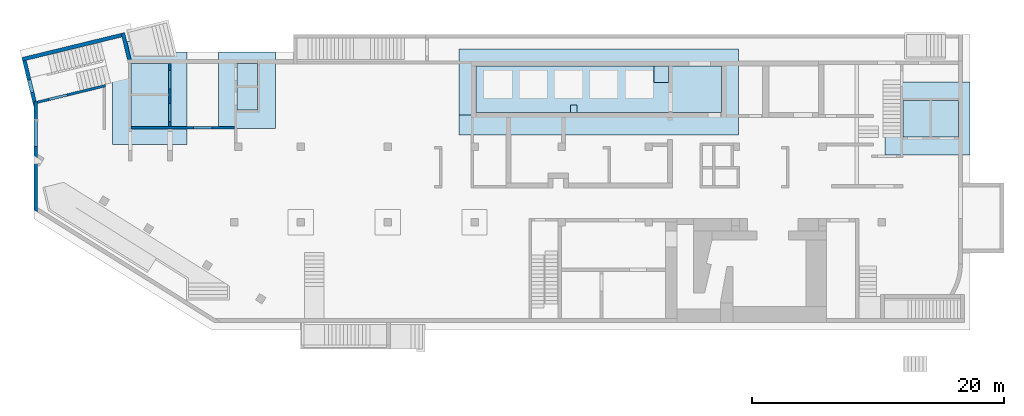
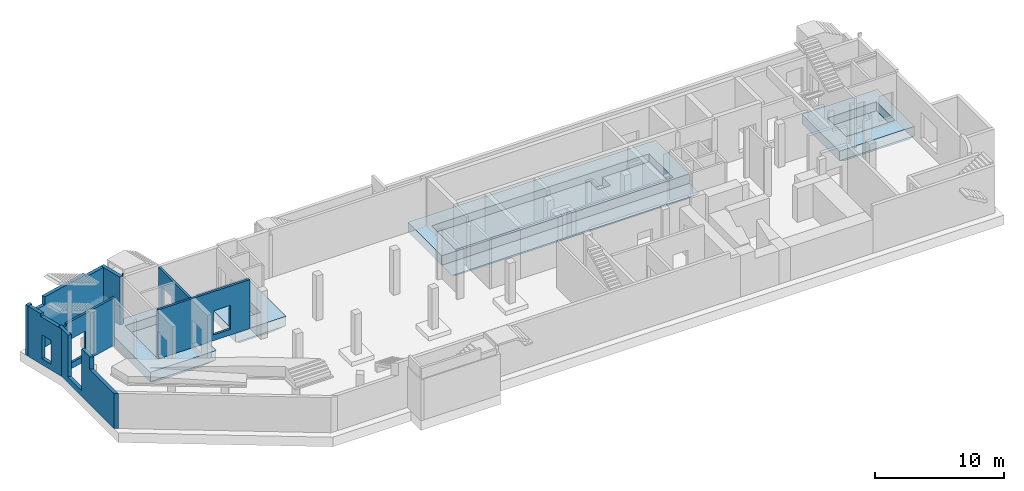
# One storey, part 5 of 9: 7 walls, 4 slabs, 7 openings.
"""IFC4 building model written with IfcOpenShell, lengths in millimetres."""

from ifc_helpers import new_model, entity, si_unit, converted_unit, derived_unit, direction, frame, origin, place, context, subcontext, project, spatial, indexed_curve, outline, extrude, polygons, material, type_object, element, save


model = new_model("IFC4")

# Units and contexts
model_context = context("Model", 3, precision=0.01, world=origin(), true_north=direction((6.12303176911189e-17, 1.0)))
plan_context = context("Plan", 3, precision=0.01, world=origin(), true_north=direction((6.12303176911189e-17, 1.0)))
body_context = subcontext(model_context, "Body", "Model", "MODEL_VIEW")
ifc_project = project(units=[si_unit("LENGTHUNIT", "METRE", prefix="MILLI"), si_unit("AREAUNIT", "SQUARE_METRE"), si_unit("VOLUMEUNIT", "CUBIC_METRE"), converted_unit("PLANEANGLEUNIT", "DEGREE", entity("IfcRatioMeasure", 0.0174532925199433), si_unit("PLANEANGLEUNIT", "RADIAN"), dimensions=[0, 0, 0, 0, 0, 0, 0]), si_unit("MASSUNIT", "GRAM", prefix="KILO"), derived_unit("MASSDENSITYUNIT", [(si_unit("MASSUNIT", "GRAM", prefix="KILO"), 1), (si_unit("LENGTHUNIT", "METRE"), -3)]), derived_unit("MOMENTOFINERTIAUNIT", [(si_unit("LENGTHUNIT", "METRE"), 4)]), si_unit("TIMEUNIT", "SECOND"), si_unit("FREQUENCYUNIT", "HERTZ"), si_unit("THERMODYNAMICTEMPERATUREUNIT", "DEGREE_CELSIUS"), derived_unit("THERMALTRANSMITTANCEUNIT", [(si_unit("MASSUNIT", "GRAM", prefix="KILO"), 1), (si_unit("THERMODYNAMICTEMPERATUREUNIT", "KELVIN"), -1), (si_unit("TIMEUNIT", "SECOND"), -3)]), derived_unit("VOLUMETRICFLOWRATEUNIT", [(si_unit("LENGTHUNIT", "METRE"), 3), (si_unit("TIMEUNIT", "SECOND"), -1)]), derived_unit("MASSFLOWRATEUNIT", [(si_unit("MASSUNIT", "GRAM", prefix="KILO"), 1), (si_unit("TIMEUNIT", "SECOND"), -1)]), derived_unit("ROTATIONALFREQUENCYUNIT", [(si_unit("TIMEUNIT", "SECOND"), -1)]), si_unit("ELECTRICCURRENTUNIT", "AMPERE"), si_unit("ELECTRICVOLTAGEUNIT", "VOLT"), si_unit("POWERUNIT", "WATT"), si_unit("FORCEUNIT", "NEWTON", prefix="KILO"), si_unit("ILLUMINANCEUNIT", "LUX"), si_unit("LUMINOUSFLUXUNIT", "LUMEN"), si_unit("LUMINOUSINTENSITYUNIT", "CANDELA"), derived_unit("USERDEFINED", [(si_unit("MASSUNIT", "GRAM", prefix="KILO"), -1), (si_unit("LENGTHUNIT", "METRE"), -2), (si_unit("TIMEUNIT", "SECOND"), 3), (si_unit("LUMINOUSFLUXUNIT", "LUMEN"), 1)]), derived_unit("LINEARVELOCITYUNIT", [(si_unit("LENGTHUNIT", "METRE"), 1), (si_unit("TIMEUNIT", "SECOND"), -1)]), si_unit("PRESSUREUNIT", "PASCAL"), derived_unit("USERDEFINED", [(si_unit("LENGTHUNIT", "METRE"), -2), (si_unit("MASSUNIT", "GRAM", prefix="KILO"), 1), (si_unit("TIMEUNIT", "SECOND"), -2)]), derived_unit("LINEARFORCEUNIT", [(si_unit("MASSUNIT", "GRAM", prefix="KILO"), 1), (si_unit("LENGTHUNIT", "METRE"), 1), (si_unit("TIMEUNIT", "SECOND"), -2), (si_unit("LENGTHUNIT", "METRE"), -1)]), derived_unit("PLANARFORCEUNIT", [(si_unit("MASSUNIT", "GRAM", prefix="KILO"), 1), (si_unit("LENGTHUNIT", "METRE"), 1), (si_unit("TIMEUNIT", "SECOND"), -2), (si_unit("LENGTHUNIT", "METRE"), -2)])], contexts=[model_context, plan_context])

# Site, building, storey
site_placement = place(None, origin())
site = spatial("IfcSite", under=ifc_project, at=site_placement, CompositionType="ELEMENT")
building_placement = place(site_placement, origin())
building = spatial("IfcBuilding", under=site, at=building_placement, CompositionType="ELEMENT")
storey_placement = place(building_placement, frame((0.0, 0.0, -4900.0)))
storey = spatial("IfcBuildingStorey", under=building, at=storey_placement, CompositionType="ELEMENT", Elevation=-4900.0)

# Slabs
ifc_material = material()
slab_type_1 = type_object("IfcSlabType", PredefinedType="BASESLAB", material=ifc_material)
slab_1_placement = place(storey_placement, frame((67520.0, 13020.0, -1750.0)))
element("IfcSlab", 1, at=slab_1_placement, inside=storey, type_object=slab_type_1, PredefinedType="BASESLAB", context=body_context, shape_type="Tessellation", body=[
    polygons([(1450.00000000004, 4349.99999999999, 1750.0), (5850.00000000005, 4349.99999999999, 1750.0), (5850.00000000005, 1449.99999999998, 1750.0), (1450.00000000004, 1449.99999999998, 1750.0), (6750.00000000002, 5799.99999999999, 1750.0), (4.33146851719357e-11, 5799.99999999999, 1750.0), (4.33146851719357e-11, -2.16573425859679e-12, 1750.0), (6750.00000000002, -2.16573425859679e-12, 1750.0), (6750.00000000002, 4949.99999999999, 0.0), (6750.00000000002, 850.000000000025, 0.0), (850.000000000006, 850.000000000025, 0.0), (850.000000000023, 4949.99999999999, 0.0), (6750.00000000002, 5799.99999999999, 849.999999999998), (4.33146851719357e-11, 5799.99999999999, 849.999999999997), (3.46517481375486e-11, 1.51601398101775e-11, 849.999999999995), (6750.00000000002, -2.16573425859679e-12, 850.00000000002), (5850.00000000005, 4349.99999999999, 899.999999999999), (3750.00000000004, 4349.99999999999, 899.999999999999), (3550.00000000004, 4349.99999999999, 899.999999999999), (1450.00000000004, 4349.99999999999, 899.999999999999), (1450.00000000004, 1449.99999999998, 899.999999999999), (3550.00000000003, 1449.99999999998, 899.999999999999), (3750.00000000003, 1449.99999999998, 899.999999999999), (5850.00000000005, 1449.99999999998, 899.999999999999)], [[[5, 6, 7, 8], [1, 2, 3, 4]], [[9, 10, 11, 12]], [[6, 5, 13, 14]], [[7, 6, 14, 15]], [[8, 7, 15, 16]], [[5, 8, 16, 10, 9, 13]], [[11, 10, 16, 15]], [[9, 12, 14, 13]], [[12, 11, 15, 14]], [[17, 18, 19, 20, 21, 22, 23, 24]], [[2, 1, 20, 19, 18, 17]], [[1, 4, 21, 20]], [[4, 3, 24, 23, 22, 21]], [[3, 2, 17, 24]]], closed=True),
])
slab_type_2 = type_object("IfcSlabType", PredefinedType="BASESLAB", material=ifc_material)
slab_2_placement = place(storey_placement, frame((14650.0, 15150.0, -1750.0)))
element("IfcSlab", 2, at=slab_2_placement, inside=storey, type_object=slab_type_2, PredefinedType="BASESLAB", context=body_context, shape_type="Tessellation", body=[
    polygons([(-2.16573425859679e-12, 6050.00000000001, 1750.00000000001), (1.08286712929839e-11, 0.0, 1750.00000000001), (4525.0, 8.66293703438714e-12, 1750.00000000001), (4524.99999999999, 6050.00000000001, 1750.00000000001), (1450.00000000001, 1450.0, 1750.0), (1450.0, 5150.0, 1750.0), (3075.0, 5150.00000000001, 1750.0), (3075.0, 5100.00000000023, 1750.00000000001), (3075.00000000001, 1450.00000000001, 1750.0), (849.999999999993, 6050.00000000001, 4.33146851719357e-12), (3674.99999999997, 6050.00000000001, 3.24860138789518e-12), (3674.99999999998, 849.99999999998, 5.41433564649196e-12), (850.000000000002, 849.999999999995, 3.24860138789518e-12), (-2.16573425859679e-12, 6050.00000000001, 850.0), (1.08286712929839e-11, 0.0, 850.000000000001), (4524.99999999998, 6.49720277579036e-12, 850.000000000001), (4524.99999999999, 6050.00000000001, 850.00000000002), (1450.0, 5150.0, 900.000000000003), (1450.00000000001, 1450.0, 900.000000000003), (3075.00000000001, 1450.00000000001, 900.000000000003), (3075.0, 5150.00000000001, 900.000000000003)], [[[1, 2, 3, 4], [5, 6, 7, 8, 9]], [[10, 11, 12, 13]], [[2, 1, 14, 15]], [[3, 2, 15, 16]], [[4, 3, 16, 17]], [[1, 4, 17, 11, 10, 14]], [[12, 11, 17, 16]], [[10, 13, 15, 14]], [[13, 12, 16, 15]], [[18, 19, 20, 21]], [[6, 5, 19, 18]], [[5, 9, 20, 19]], [[9, 8, 7, 21, 20]], [[7, 6, 18, 21]]], closed=True),
])
slab_type_3 = type_object("IfcSlabType", PredefinedType="BASESLAB", material=ifc_material)
slab_3_placement = place(storey_placement, frame((6250.0, 13850.0, -1750.0)))
element("IfcSlab", 3, at=slab_3_placement, inside=storey, type_object=slab_type_3, PredefinedType="BASESLAB", context=body_context, shape_type="Tessellation", body=[
    polygons([(-1.08286712929839e-12, 8200.00000000004, 1750.00000000001), (1.40772726808791e-11, 3.68174823961454e-11, 1750.00000000001), (5900.00000000001, 4.54804194305325e-11, 1750.00000000001), (5900.0, 7350.00000000009, 1750.00000000001), (1950.50878437107, 7350.0000000001, 1750.0), (1743.31229154819, 8200.00000000004, 1750.00000000001), (1450.00000000001, 1450.00000000004, 1750.0), (1450.0, 6450.00000000009, 1750.0), (4450.0, 6450.0000000001, 1750.0), (4450.00000000001, 1450.00000000005, 1750.0), (5049.99999999999, 849.999999999991, 3.24860138789518e-12), (850.000000000003, 850.000000000015, 4.33146851719357e-12), (849.999999999993, 7350.00000000009, 3.24860138789518e-12), (1950.50878437107, 7350.0000000001, 4.33146851719357e-12), (5049.99999999998, 7350.00000000009, 5.41433564649196e-12), (3.24860138789518e-12, 8200.00000000005, 849.999999999984), (1.40772726808791e-11, 3.46517481375486e-11, 849.999999999995), (5900.00000000001, 3.46517481375486e-11, 849.999999999996), (5900.0, 7350.00000000009, 850.00000000002), (1743.31229154819, 8200.00000000004, 849.999999999957), (1450.0, 6450.00000000009, 900.000000000003), (1450.00000000001, 1450.00000000004, 900.000000000003), (4450.00000000001, 1450.00000000005, 900.000000000003), (4450.0, 6450.0000000001, 900.000000000003)], [[[1, 2, 3, 4, 5, 6], [7, 8, 9, 10]], [[11, 12, 13, 14, 15]], [[2, 1, 16, 17]], [[3, 2, 17, 18]], [[3, 18, 19, 4]], [[16, 1, 6, 20]], [[18, 11, 15, 19]], [[17, 16, 13, 12]], [[12, 11, 18, 17]], [[21, 22, 23, 24]], [[8, 7, 22, 21]], [[7, 10, 23, 22]], [[10, 9, 24, 23]], [[9, 8, 21, 24]], [[13, 16, 20, 14]], [[5, 4, 19, 15, 14]], [[6, 5, 14, 20]]], closed=True),
])
slab_type_4 = type_object("IfcSlabType", PredefinedType="BASESLAB", material=ifc_material)
slab_4_placement = place(storey_placement, frame((33720.0, 14600.0, -1800.0)))
element("IfcSlab", 4, at=slab_4_placement, inside=storey, type_object=slab_type_4, PredefinedType="BASESLAB", context=body_context, shape_type="Tessellation", body=[
    polygons([(22200.0, 6850.00000000012, 1800.0), (-4.33146851719357e-12, 6850.00000000008, 1800.0), (8.66293703438714e-12, 1600.00000000008, 1800.0), (22200.0, 1600.00000000012, 1800.0), (20850.0, 5500.00000000027, 1800.00000000001), (20850.0, 1800.00000000025, 1800.00000000001), (1350.00000000001, 1800.00000000021, 1800.00000000001), (1350.00000000001, 5500.00000000024, 1800.00000000001), (21450.0, 750.000000000005, 150.000000000005), (750.00000000002, 750.000000000109, 150.000000000004), (750.000000000016, 3850.00000000021, 150.000000000005), (750.000000000011, 6100.00000000015, 150.000000000005), (15150.0, 6100.00000000015, 150.000000000005), (15150.0, 5500.00000000026, 150.000000000005), (15150.0, 3850.00000000016, 150.000000000002), (17000.0, 3850.00000000016, 150.000000000008), (17000.0, 5500.00000000026, 150.000000000005), (17000.0, 6100.00000000015, 150.000000000006), (21450.0, 6100.00000000015, 150.000000000005), (21450.0, 3850.00000000015, 150.000000000005), (4.33146851719357e-12, 6850.00000000009, 899.999999999995), (1.29944055515807e-11, 1600.00000000008, 900.000000000014), (22200.0, 6850.00000000012, 899.99999999999), (22200.0, 1600.00000000012, 900.000000000003), (1350.00000000001, 5500.00000000024, 1050.00000000001), (15500.0, 5500.00000000023, 1050.00000000001), (15500.0, 5500.00000000017, 300.000000000005), (16650.0, 5500.0000000002, 300.000000000005), (16650.0, 5500.00000000027, 1050.00000000001), (16950.0, 5500.00000000027, 1050.00000000001), (20850.0, 5500.00000000027, 1050.00000000001), (15300.0, 5950.00000000015, 3.24860138789518e-12), (16850.0, 5950.00000000015, 5.41433564649196e-12), (16850.0, 4000.00000000016, 7.58006990508875e-12), (15300.0, 4000.00000000016, 7.58006990508875e-12), (22200.0, 5.84748249821132e-11, 899.999999999991), (1.29944055515807e-11, 9.52923073782586e-11, 900.000000000013), (1350.00000000001, 1800.00000000021, 1050.00000000001), (8860.00000000002, 1800.00000000022, 1050.00000000001), (8860.00000000002, 2400.00000000022, 1050.00000000001), (9360.00000000002, 2400.00000000022, 1050.00000000001), (9360.00000000002, 1800.00000000022, 1050.00000000001), (16650.0, 1800.00000000024, 1050.00000000001), (16950.0, 1800.00000000024, 1050.00000000001), (20850.0, 1800.00000000025, 1050.00000000001), (16650.0, 4200.00000000016, 1050.00000000001), (15500.0, 4200.00000000016, 1050.00000000001), (9360.00000000002, 1800.00000000022, 800.000000000005), (8860.00000000002, 1800.00000000022, 800.000000000005), (9360.00000000002, 2400.00000000022, 800.000000000005), (8860.00000000002, 2400.00000000022, 800.000000000005), (15500.0, 4200.00000000016, 300.000000000005), (16650.0, 4200.00000000016, 300.000000000005)], [[[1, 2, 3, 4], [5, 6, 7, 8]], [[9, 10, 11, 12, 13, 14, 15, 16, 17, 18, 19, 20]], [[2, 21, 22, 3]], [[23, 1, 4, 24]], [[2, 1, 23, 21]], [[8, 25, 26, 27, 28, 29, 30, 31, 5]], [[32, 33, 34, 35]], [[20, 19, 23, 24, 36, 9]], [[11, 10, 37, 22, 21, 12]], [[10, 9, 36, 37]], [[25, 38, 39, 40, 41, 42, 43, 44, 45, 31, 30, 29, 46, 47, 26]], [[8, 7, 38, 25]], [[7, 6, 45, 44, 43, 42, 48, 49, 39, 38]], [[6, 5, 31, 45]], [[33, 32, 13, 12, 21, 23, 19, 18]], [[49, 48, 50, 51]], [[42, 41, 50, 48]], [[41, 40, 51, 50]], [[40, 39, 49, 51]], [[35, 34, 16, 15]], [[34, 33, 18, 17, 16]], [[32, 35, 15, 14, 13]], [[28, 27, 52, 53]], [[26, 47, 52, 27]], [[47, 46, 53, 52]], [[46, 29, 28, 53]], [[24, 22, 37, 36]], [[22, 24, 4, 3]]], closed=True),
])

# Wall, openings
wall_type_1 = type_object("IfcWallType", Name=":ADSK_ 25_200", PredefinedType="STANDARD")
wall_1_placement = place(storey_placement, frame((10800.0, 20300.0, 0.0), z_axis=(0.0, 0.0, 1.0), x_axis=(0.0, -1.0, 0.0)))
wall_1 = element("IfcWall", 5, at=wall_1_placement, inside=storey, type_object=wall_type_1, material=ifc_material, Name=":ADSK_ 25_200", ObjectType=":ADSK_ 25_200", PredefinedType="NOTDEFINED", context=body_context, shape_type="Tessellation", body=[
    polygons([(579.999999999998, -100.000000000002, 2919.99999999804), (2020.0, -100.000000000002, 2919.99999999804), (2020.0, -100.000000000002, 550.0), (579.999999999998, -100.000000000002, 550.0), (3180.0, -100.000000000002, 2919.99999999804), (4620.0, -100.000000000002, 2919.99999999804), (4620.0, -100.000000000002, 550.0), (3180.0, -100.000000000002, 550.0), (0.0, -100.000000000002, 0.0), (2399.99999999999, -100.000000000001, 0.0), (2599.99999999999, -100.000000000001, 0.0), (5000.00000000048, -100.000000000002, 0.0), (5000.00000000048, -100.000000000002, 4500.0), (0.0, -100.000000000002, 4500.0), (5000.00000000048, 99.9999999999976, 0.0), (0.0, 99.9999999999985, 0.0), (0.0, 99.9999999999985, 4500.0), (5000.00000000048, 99.9999999999976, 4500.0), (2020.0, 99.9999999999977, 2919.99999999804), (579.999999999998, 99.9999999999976, 2919.99999999804), (579.999999999998, 99.9999999999976, 550.0), (2020.0, 99.9999999999977, 550.0), (4620.0, 99.9999999999982, 2919.99999999804), (3180.0, 99.9999999999981, 2919.99999999804), (3180.0, 99.9999999999981, 550.0), (4620.0, 99.9999999999982, 550.0)], [[[9, 10, 11, 12, 13, 14], [1, 2, 3, 4], [5, 6, 7, 8]], [[15, 16, 17, 18], [19, 20, 21, 22], [23, 24, 25, 26]], [[12, 11, 10, 9, 16, 15]], [[14, 13, 18, 17]], [[9, 14, 17, 16]], [[13, 12, 15, 18]], [[19, 2, 1, 20]], [[20, 1, 4, 21]], [[21, 4, 3, 22]], [[2, 19, 22, 3]], [[23, 6, 5, 24]], [[24, 5, 8, 25]], [[25, 8, 7, 26]], [[6, 23, 26, 7]]], closed=True),
])
placement_1 = place(wall_1_placement, frame((20300.0, -10800.0, 0.0), z_axis=(0.0, 0.0, 1.0), x_axis=(0.0, 1.0, 0.0)))
element("IfcOpeningElement", 6, at=placement_1, cuts=wall_1, Name=":ADSK_ 25_200", PredefinedType="OPENING", context=body_context, shape_type="SweptSolid", body=[
    extrude(outline(indexed_curve([(-1184.99999999902, -719.999999999999), (1184.99999999902, -719.999999999999), (1184.99999999902, 720.000000000001), (-1184.99999999902, 720.000000000001), (-1184.99999999902, -719.999999999999)], self_intersect=False)), frame((10600.0, 19000.0, 1735.0), z_axis=(1.0, 0.0, 0.0), x_axis=(0.0, 0.0, -1.0)), (0.0, 0.0, 1.0), 400.000000001943),
])
element("IfcOpeningElement", 7, at=placement_1, cuts=wall_1, Name=":ADSK_ 25_200", PredefinedType="OPENING", context=body_context, shape_type="SweptSolid", body=[
    extrude(outline(indexed_curve([(-1184.99999999902, -719.999999999999), (1184.99999999902, -719.999999999999), (1184.99999999902, 720.000000000001), (-1184.99999999902, 720.000000000001), (-1184.99999999902, -719.999999999999)], self_intersect=False)), frame((10600.0, 16400.0, 1735.0), z_axis=(1.0, 0.0, 0.0), x_axis=(0.0, 0.0, -1.0)), (0.0, 0.0, 1.0), 400.000000001943),
])

# Wall, opening
wall_2_placement = place(storey_placement, frame((7700.0, 15200.0, 0.0)))
wall_2 = element("IfcWall", 8, at=wall_2_placement, inside=storey, type_object=wall_type_1, material=ifc_material, Name=":ADSK_ 25_200", ObjectType=":ADSK_ 25_200", PredefinedType="NOTDEFINED", context=body_context, shape_type="Tessellation", body=[
    polygons([(1.8769719247939e-12, -100.000000000001, 0.0), (99.9999999999986, -100.000000000001, 0.0), (2900.0, -100.000000000001, 0.0), (3300.0, -99.9999999999989, 0.0), (8199.99999999999, -99.9999999999989, 0.0), (8199.99999999999, -99.9999999999989, 4650.0), (3300.0, -99.9999999999989, 4650.0), (2900.0, -100.000000000001, 4650.0), (99.9999999999986, -100.000000000001, 4650.0), (1.8769719247939e-12, -100.000000000001, 4650.0), (1.8769719247939e-12, -100.000000000001, 4500.0), (4950.0, -100.000000000003, 2829.99999999804), (6450.0, -100.000000000001, 2829.99999999805), (6450.0, -100.000000000001, 550.0), (4950.0, -100.000000000003, 550.0), (8199.99999999999, 99.9999999999989, 0.0), (3200.0, 100.000000000001, 0.0), (3000.0, 99.9999999999989, 0.0), (2.16575659869695e-13, 100.000000000001, 0.0), (2.16575659869695e-13, 100.000000000001, 4650.0), (8199.99999999999, 99.9999999999989, 4650.0), (6450.0, 99.9999999999989, 2829.99999999805), (4950.0, 99.9999999999989, 2829.99999999804), (4950.0, 99.9999999999989, 550.0), (6450.0, 99.9999999999989, 550.0)], [[[1, 2, 3, 4, 5, 6, 7, 8, 9, 10, 11], [12, 13, 14, 15]], [[16, 17, 18, 19, 20, 21], [22, 23, 24, 25]], [[5, 4, 3, 2, 1, 19, 18, 17, 16]], [[10, 9, 8, 7, 6, 21, 20]], [[1, 11, 10, 20, 19]], [[6, 5, 16, 21]], [[22, 13, 12, 23]], [[23, 12, 15, 24]], [[24, 15, 14, 25]], [[13, 22, 25, 14]]], closed=True),
])
opening_3_placement = place(wall_2_placement, frame((-7700.0, -15200.0, 0.0)))
element("IfcOpeningElement", 9, at=opening_3_placement, cuts=wall_2, Name=":ADSK_ 25_200", PredefinedType="OPENING", context=body_context, shape_type="SweptSolid", body=[
    extrude(outline(indexed_curve([(-1139.99999999902, -749.999999999998), (1139.99999999902, -749.999999999998), (1139.99999999902, 750.000000000001), (-1139.99999999902, 750.000000000001), (-1139.99999999902, -749.999999999998)], self_intersect=False)), frame((13400.0, 15000.0, 1690.0), z_axis=(0.0, 1.0, 0.0), x_axis=(0.0, 0.0, -1.0)), (0.0, 0.0, 1.0), 400.000000001943),
])

# Wall
wall_3_placement = place(storey_placement, frame((276.32, 17216.05, 0.0), z_axis=(0.0, 0.0, 1.0), x_axis=(0.971552058141472, 0.236826092990341, 0.0)))
element("IfcWall", 10, at=wall_3_placement, inside=storey, type_object=wall_type_1, material=ifc_material, Name=":ADSK_ 25_200", ObjectType=":ADSK_ 25_200", PredefinedType="NOTDEFINED", context=body_context, shape_type="Tessellation", body=[
    polygons([(-5.41433564649196e-13, -100.000000000001, 0.0), (5352.26080416868, -100.000000000001, 0.0), (5558.1169889444, -100.000000000003, 0.0), (5558.1169889444, -100.000000000001, 4500.0), (5352.26080416868, -100.000000000001, 4500.0), (400.27581160053, -99.9999999999968, 4500.0), (400.27581160053, -100.000000000319, 4300.00000000001), (0.275811600527082, -100.000000000319, 4300.00000000001), (0.275811600527082, -100.000000000001, 4500.0), (0.0, -100.000000000001, 4500.0), (942.275811600532, -100.000000000003, 2829.99999999804), (2442.27581160053, -100.000000000003, 2829.99999999805), (2442.27581160053, -100.000000000003, 550.0), (942.275811600532, -100.000000000003, 550.0), (5606.86910490273, 99.9999999999968, 0.0), (48.7521159583319, 99.9999999999989, 0.0), (48.7521159583308, 99.9999999999989, 4300.00000000001), (400.275811600528, 99.9999999999989, 4300.00000000001), (400.275811600528, 99.9999999999989, 4500.0), (5606.86910490273, 99.9999999999989, 4500.0), (2442.27581160054, 100.000000000001, 2829.99999999805), (942.275811600533, 99.9999999999968, 2829.99999999804), (942.275811600534, 100.000000000001, 550.0), (2442.27581160054, 100.000000000001, 550.0), (0.275811600528165, -98.8685143399134, 4500.0), (0.275811600528165, -98.8685143399134, 4300.00000000001)], [[[1, 2, 3, 4, 5, 6, 7, 8, 9, 10], [11, 12, 13, 14]], [[15, 16, 17, 18, 19, 20], [21, 22, 23, 24]], [[3, 2, 1, 16, 15]], [[4, 3, 15, 20]], [[16, 1, 10, 25, 26, 17]], [[10, 9, 25]], [[21, 12, 11, 22]], [[22, 11, 14, 23]], [[23, 14, 13, 24]], [[12, 21, 24, 13]], [[18, 7, 6, 19]], [[7, 18, 17, 26, 8]], [[8, 26, 25, 9]], [[4, 20, 19, 6, 5]]], closed=True),
])

# Wall, opening
wall_type_2 = type_object("IfcWallType", Name=":ADSK_ 25_300", PredefinedType="STANDARD")
placement_2 = place(storey_placement, frame((7058.34, 22718.75, 0.0), z_axis=(0.0, 0.0, 1.0), x_axis=(0.236826092990336, -0.971552058141474, 0.0)))
wall_4 = element("IfcWall", 11, at=placement_2, inside=storey, type_object=wall_type_2, material=ifc_material, Name=":ADSK_ 25_300", ObjectType=":ADSK_ 25_300", PredefinedType="NOTDEFINED", context=body_context, shape_type="Tessellation", body=[
    polygons([(4.33146851719357e-12, -149.999999999999, 0.0), (300.000000000005, -149.999999999999, 0.0), (2144.22404517247, -149.999999999999, 0.0), (2144.22404517247, -149.999999999999, 1670.0), (300.000000000005, -149.999999999998, 1670.0), (300.000000000005, -149.999999999998, 1870.0), (2144.22404517247, -149.999999999999, 1870.0), (2144.22404517246, -149.999999999999, 4500.0), (300.000000000005, -149.999999999999, 4500.0), (4.33146851719357e-12, -149.999999999999, 4500.0), (2217.35221910996, 150.000000000001, 0.0), (4.33146851719357e-12, 150.000000000003, 0.0), (4.33146851719357e-12, 150.000000000002, 4500.0), (2094.06944418373, 150.000000000003, 4500.0), (2094.06944418374, 150.000000000003, 4750.0), (2217.35221910996, 150.000000000001, 4750.0), (2210.43770763277, 121.634004632318, 4750.0), (2210.43770763277, 121.634004632318, 4650.0), (2210.43770763277, 121.634004632318, 4500.0), (2145.75382931356, -143.724234893089, 1870.0), (2145.75382931356, -143.724234893089, 1670.0), (300.000000000005, -143.724234893084, 1670.0), (300.000000000005, -143.724234893084, 1870.0)], [[[1, 2, 3, 4, 5, 6, 7, 8, 9, 10]], [[11, 12, 13, 14, 15, 16]], [[3, 2, 1, 12, 11]], [[16, 15, 17]], [[3, 11, 16, 17, 18, 19, 8, 7, 20, 21, 4]], [[12, 1, 10, 13]], [[19, 14, 13, 10, 9, 8]], [[14, 19, 18, 17, 15]], [[21, 22, 5, 4]], [[6, 23, 20, 7]], [[22, 23, 6, 5]], [[23, 22, 21, 20]]], closed=True),
])
element("IfcOpeningElement", 12, at=placement_2, cuts=wall_4, Name=":ADSK_ 25_300:1", PredefinedType="OPENING", context=body_context, shape_type="SweptSolid", body=[
    extrude(outline(indexed_curve([(-923.25936069205, -3.13788255345677), (922.494468621501, -3.13788255345677), (922.494468621501, 3.13788255345893), (-921.729576550957, 3.13788255345464), (-923.25936069205, -3.13788255345677)], self_intersect=False)), frame((1222.49, -146.86, 1670.0), z_axis=(0.0, 0.0, 1.0), x_axis=(-1.0, 0.0, 0.0)), (0.0, 0.0, 1.0), 200.0),
])

wall_5_placement = place(storey_placement, frame((6948.13, 22537.49, 0.0), z_axis=(0.0, 0.0, 1.0), x_axis=(-0.971552058141474, -0.236826092990335, 0.0)))
wall_5 = element("IfcWall", 13, at=wall_5_placement, inside=storey, type_object=wall_type_2, material=ifc_material, Name=":ADSK_ 25_300", ObjectType=":ADSK_ 25_300", PredefinedType="NOTDEFINED", context=body_context, shape_type="Tessellation", body=[
    polygons([(1.08286712929839e-12, -150.000000000001, 0.0), (8099.99206966279, -150.000000000001, 0.0), (8099.99206966279, -150.000000000001, 4750.0), (7649.99206966279, -150.000000000005, 4750.0), (7649.99206966279, -150.000000000005, 3970.00000000001), (6299.99206966279, -150.000000000005, 3970.00000000001), (6299.99206966279, -149.999999999996, 4750.0), (1900.00000000001, -150.000000000005, 4750.0), (1900.00000000001, -150.000000000001, 4500.0), (1.08286712929839e-12, -150.000000000001, 4500.0), (8099.99206966279, 150.000000000001, 0.0), (7799.99206966279, 150.000000000001, 0.0), (-1.08286712929839e-12, 150.000000000001, 0.0), (0.0, 150.000000000001, 1670.0), (0.0, 150.000000000001, 1870.0), (-1.08286712929839e-12, 150.000000000001, 4500.0), (1900.00000000002, 150.000000000001, 4500.0), (1900.00000000002, 149.999999999996, 4750.0), (1930.93783039304, 150.000000000001, 4750.0), (6299.99206966279, 150.000000000001, 4750.0), (6299.99206966279, 150.000000000321, 3970.00000000001), (7649.99206966279, 150.000000000321, 3970.00000000001), (7649.99206966279, 150.000000000001, 4750.0), (7799.99206966279, 150.000000000001, 4750.0), (8099.99206966279, 150.000000000001, 4750.0), (7649.99206966278, -49.999999999993, 4750.0), (6299.99206966278, -49.9999999999973, 4750.0)], [[[1, 2, 3, 4, 5, 6, 7, 8, 9, 10]], [[11, 12, 13, 14, 15, 16, 17, 18, 19, 20, 21, 22, 23, 24, 25]], [[2, 1, 13, 12, 11]], [[3, 25, 24, 23, 26, 4]], [[13, 1, 10, 16, 15, 14]], [[3, 2, 11, 25]], [[6, 21, 20, 27, 7]], [[21, 6, 5, 22]], [[22, 5, 4, 26, 23]], [[9, 17, 16, 10]], [[17, 9, 8, 18]], [[7, 27, 20, 19, 18, 8]]], closed=True),
])
opening_5_placement = place(wall_5_placement, frame((12087.93, 20250.85, 0.0), z_axis=(0.0, 0.0, 1.0), x_axis=(-0.971552058141474, 0.236826092990335, 0.0)))
element("IfcOpeningElement", 14, at=opening_5_placement, cuts=wall_5, Name=":ADSK_ 25_300", PredefinedType="OPENING", context=body_context, shape_type="SweptSolid", body=[
    extrude(outline(indexed_curve([(-1089.99999999999, -675.0), (1089.99999999999, -675.0), (1089.99999999999, 675.0), (-1089.99999999999, 675.0), (-1089.99999999999, -675.0)], self_intersect=False)), frame((136.04, 21031.36, 5060.0), z_axis=(0.236826092990334, -0.971552058141474, 0.0), x_axis=(0.0, 0.0, -1.0)), (0.0, 0.0, 1.0), 300.000000000971),
])

# Wall, openings
wall_6_placement = place(storey_placement, frame((-740.18, 20508.99, 0.0), z_axis=(0.0, 0.0, 1.0), x_axis=(0.236826092990336, -0.971552058141473, 0.0)))
wall_6 = element("IfcWall", 15, at=wall_6_placement, inside=storey, type_object=wall_type_2, material=ifc_material, Name=":ADSK_ 25_300", ObjectType=":ADSK_ 25_300", PredefinedType="NOTDEFINED", context=body_context, shape_type="Tessellation", body=[
    polygons([(8.66293703438714e-12, -150.000000000001, 0.0), (3740.77040872538, -149.999999999999, 0.0), (3740.77040872538, -150.0, 4500.0), (1420.00000000001, -150.000000000001, 4500.0), (1420.00000000001, -150.0, 4750.0), (4.33146851719357e-12, -150.000000000001, 4750.0), (1570.00000000005, -150.000000000001, 2829.99999999804), (2590.00000000005, -149.999999999999, 2829.99999999805), (2590.00000000005, -149.999999999999, 550.0), (1570.00000000005, -150.0, 550.0), (3340.00000000005, 150.000000000001, 0.0), (8.66293703438714e-12, 150.0, 0.0), (8.66293703438714e-12, 150.0, 4750.0), (1420.00000000001, 150.000000000001, 4750.0), (1420.00000000001, 150.000000000001, 4500.0), (3340.00000000005, 150.000000000001, 4500.0), (2590.00000000006, 150.0, 2829.99999999805), (1570.00000000005, 150.000000000001, 2829.99999999804), (1570.00000000005, 150.000000000001, 550.0), (2590.00000000005, 150.000000000001, 550.0), (3340.00000000005, -52.3079728057761, 0.0), (3340.00000000006, -52.3079728057772, 4500.0)], [[[1, 2, 3, 4, 5, 6], [7, 8, 9, 10]], [[11, 12, 13, 14, 15, 16], [17, 18, 19, 20]], [[2, 1, 12, 11, 21]], [[13, 6, 5, 14]], [[1, 6, 13, 12]], [[21, 11, 16, 22]], [[2, 21, 22, 3]], [[15, 4, 3, 22, 16]], [[4, 15, 14, 5]], [[17, 8, 7, 18]], [[18, 7, 10, 19]], [[19, 10, 9, 20]], [[8, 17, 20, 9]]], closed=True),
])
opening_6_placement = place(wall_6_placement, origin())
element("IfcOpeningElement", 16, at=opening_6_placement, cuts=wall_6, Name=":ADSK_ 25_300", PredefinedType="OPENING", context=body_context, shape_type="SweptSolid", body=[
    extrude(outline(indexed_curve([(-150.000000000483, -1089.99999999999), (150.000000000484, -1089.99999999999), (150.000000000478, 1089.99999999999), (-150.000000000484, 1089.99999999999), (-150.000000000483, -1089.99999999999)], self_intersect=False)), frame((-150.0, 300.0, 5060.0), z_axis=(0.0, 1.0, 0.0), x_axis=(-1.0, 0.0, 0.0)), (0.0, 0.0, 1.0), 1350.0),
])
opening_7_placement = place(wall_6_placement, frame((20100.85, -4137.94, 0.0), z_axis=(0.0, 0.0, 1.0), x_axis=(0.236826092990336, 0.971552058141473, 0.0)))
element("IfcOpeningElement", 17, at=opening_7_placement, cuts=wall_6, Name=":ADSK_ 25_300", PredefinedType="OPENING", context=body_context, shape_type="SweptSolid", body=[
    extrude(outline(indexed_curve([(-1139.99999999902, -509.999999999999), (1139.99999999902, -509.999999999999), (1139.99999999902, 510.000000000002), (-1139.99999999902, 510.000000000002), (-1139.99999999902, -509.999999999999)], self_intersect=False)), frame((-490.47, 18428.96, 1690.0), z_axis=(0.971552058141474, 0.236826092990336, 0.0), x_axis=(0.0, 0.0, -1.0)), (0.0, 0.0, 1.0), 500.000000001943),
])

# Wall
wall_7_placement = place(storey_placement, frame((150.0, 8501.7, 0.0), z_axis=(0.0, 0.0, 1.0), x_axis=(0.0, 1.0, 0.0)))
element("IfcWall", 18, at=wall_7_placement, inside=storey, type_object=wall_type_2, material=ifc_material, Name=":ADSK_ 25_300", ObjectType=":ADSK_ 25_300", PredefinedType="NOTDEFINED", context=body_context, shape_type="Tessellation", body=[
    polygons([(1.08286712929839e-12, -150.0, 0.0), (353.751582317484, -150.0, 0.0), (8617.19683579752, -150.0, 0.0), (8823.05302057324, -150.0, 0.0), (8823.05302057324, -150.0, 4300.00000000001), (8618.36145240309, -150.0, 4300.00000000001), (8618.36145240309, -150.0, 4500.0), (8617.19683579751, -150.0, 4500.0), (7298.30250806127, -150.0, 4500.0), (7298.30250806127, -150.0, 550.0), (5198.30250806128, -150.0, 550.0), (5198.30250806128, -150.0, 4500.0), (4598.77057012725, -150.0, 4500.0), (3773.35021138651, -150.0, 4500.0), (3773.35021138651, -150.0, 3330.0), (353.751582317485, -150.0, 3330.0), (1.19115384222823e-11, -150.0, 3330.0), (8749.92484663574, 150.0, 0.0), (8337.41951007973, 150.0, 0.0), (187.457147082003, 150.0, 0.0), (187.457147082003, 150.0, 3330.0), (3960.80735846851, 150.000000000003, 3330.0), (3960.80735846851, 150.000000000004, 3580.0), (3960.80735846851, 150.000000000003, 4500.0), (5198.30250806128, 150.000000000001, 4500.0), (5198.30250806128, 150.0, 550.0), (7298.30250806127, 150.0, 550.0), (7298.30250806127, 150.0, 4500.0), (8337.41951007972, 150.0, 4500.0), (8749.92484663574, 150.0, 4500.0), (8797.83665341613, -46.5527273578813, 0.0), (8797.83665341613, -46.5527273578805, 4500.0), (8811.57256680957, -102.902746730084, 4500.0), (8811.57256680957, -102.902746730084, 4300.00000000001)], [[[1, 2, 3, 4, 5, 6, 7, 8, 9, 10, 11, 12, 13, 14, 15, 16, 17]], [[18, 19, 20, 21, 22, 23, 24, 25, 26, 27, 28, 29, 30]], [[4, 3, 2, 1, 20, 19, 18, 31]], [[1, 17, 21, 20]], [[24, 14, 13, 12, 25]], [[14, 24, 23, 22, 15]], [[17, 16, 15, 22, 21]], [[4, 31, 18, 30, 32, 33, 34, 5]], [[34, 6, 5]], [[6, 34, 33, 7]], [[27, 10, 9, 28]], [[10, 27, 26, 11]], [[11, 26, 25, 12]], [[30, 29, 28, 9, 8, 7, 33, 32]]], closed=True),
])

save(model, "model.ifc")
